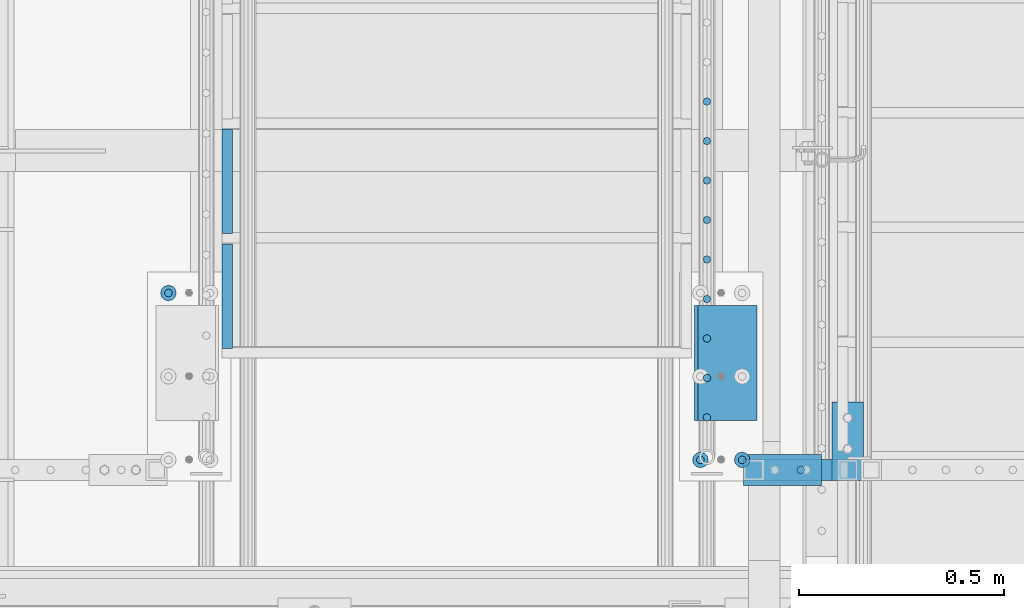
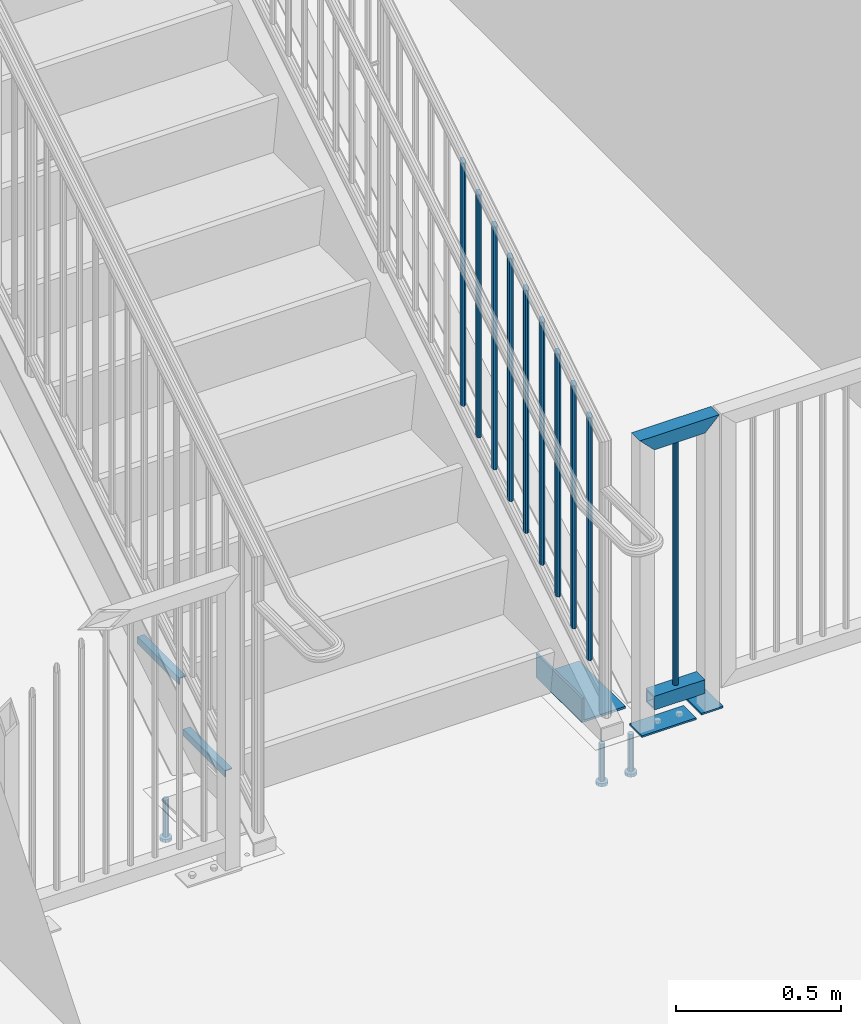
# One storey, part 1260 of 1763: 20 beams, 5 elements without a shape of their own.
"""IFC2X3 building model written with IfcOpenShell, lengths in millimetres."""

from ifc_helpers import new_model, si_unit, frame, origin_with_axes, place, context, subcontext, project, spatial, faceted_brep, material, type_object, element, aggregate, save


model = new_model("IFC2X3")

# Units and contexts
model_context = context("Model", 3, precision=1e-05, world=origin_with_axes())
body_context = subcontext(model_context, "Body", "Model", "MODEL_VIEW")
ifc_project = project(units=[si_unit("LENGTHUNIT", "METRE", prefix="MILLI"), si_unit("AREAUNIT", "SQUARE_METRE"), si_unit("VOLUMEUNIT", "CUBIC_METRE"), si_unit("MASSUNIT", "GRAM", prefix="KILO"), si_unit("TIMEUNIT", "SECOND"), si_unit("PLANEANGLEUNIT", "RADIAN"), si_unit("SOLIDANGLEUNIT", "STERADIAN"), si_unit("THERMODYNAMICTEMPERATUREUNIT", "DEGREE_CELSIUS"), si_unit("LUMINOUSINTENSITYUNIT", "LUMEN")], contexts=[model_context])

# Site, building, storey
site_placement = place(None, origin_with_axes())
site = spatial("IfcSite", under=ifc_project, at=site_placement, CompositionType="ELEMENT")
building_placement = place(site_placement, origin_with_axes())
building = spatial("IfcBuilding", under=site, at=building_placement, Name="Undefined", CompositionType="ELEMENT")
storey_placement = place(building_placement, origin_with_axes())
storey = spatial("IfcBuildingStorey", under=building, at=storey_placement, Name="Undefined", CompositionType="ELEMENT", Elevation=0.0)

# Assembly, beams
assembly_1_placement = place(storey_placement, origin_with_axes())
assembly_1 = element("IfcElementAssembly", 1, at=assembly_1_placement, inside=storey, Name="GUARDRAIL", AssemblyPlace="NOTDEFINED", PredefinedType="RIGID_FRAME")
ifc_material_1 = material(Name="STEEL/A36")
beam_type_1 = type_object("IfcBeamType", PredefinedType="NOTDEFINED")
beam_1_placement = place(assembly_1_placement, frame((-85375.187267589, 32061.1500064728, 307.975030132566), z_axis=(1.0, 0.0, 0.0), x_axis=(0.0, -1.0, 0.0)))
beam_1 = element("IfcBeam", 2, at=beam_1_placement, type_object=beam_type_1, material=ifc_material_1, context=body_context, shape_type="Brep", body=[
    faceted_brep([(0.0, 3.17500000000001, -95.25), (0.0, 3.17499999999927, 95.25), (76.1999968561649, 3.17499999984284, 95.25), (76.1999999999971, 3.17500000000001, -95.25), (0.0, -3.17499999999927, 95.25), (76.1999970403122, -3.17500000015571, 95.25), (0.0, -3.17500000000001, -95.25), (76.1999999999971, -3.17500000000001, -95.25)], [[[0, 1, 2, 3]], [[1, 4, 5, 2]], [[4, 6, 7, 5]], [[6, 0, 3, 7]], [[5, 7, 3, 2]], [[6, 4, 1, 0]]]),
])
beam_2_placement = place(assembly_1_placement, frame((-85254.5046939728, 32092.8674137657, 307.975030132566), z_axis=(0.0, 1.0, 0.0), x_axis=(1.0, 0.0, 0.0)))
beam_2 = element("IfcBeam", 3, at=beam_2_placement, type_object=beam_type_1, material=ifc_material_1, context=body_context, shape_type="Brep", body=[
    faceted_brep([(0.0, 3.17500000000001, -95.25), (0.0, 3.17499999999927, 95.25), (76.1999968561649, 3.17499999984284, 95.25), (76.1999999999971, 3.17500000000001, -95.25), (0.0, -3.17499999999927, 95.25), (76.1999970403122, -3.17500000015571, 95.25), (0.0, -3.17500000000001, -95.25), (76.1999999999971, -3.17500000000001, -95.25)], [[[0, 1, 2, 3]], [[1, 4, 5, 2]], [[4, 6, 7, 5]], [[6, 0, 3, 7]], [[5, 7, 3, 2]], [[6, 4, 1, 0]]]),
])
beam_type_2 = type_object("IfcBeamType", PredefinedType="NOTDEFINED")
beam_3_placement = place(assembly_1_placement, frame((-85330.7372706616, 32023.0500064728, 1346.20003013257), z_axis=(1.0, 0.0, 0.0), x_axis=(0.0, 0.0, -1.0)))
beam_3 = element("IfcBeam", 4, at=beam_3_placement, type_object=beam_type_2, material=ifc_material_1, Name="PICKET", context=body_context, shape_type="Brep", body=[
    faceted_brep([(0.0, -9.52500000000146, 0.0), (0.0, -6.73519209080041, -6.73519209079677), (914.401840643747, -6.73519209080041, -6.73519209079677), (914.401840643747, -9.52500000000146, 0.0), (0.0, 0.0, -9.52499999999418), (914.401840643747, 0.0, -9.52499999999418), (0.0, 6.73519209080041, -6.73519209079677), (914.401840643747, 6.73519209080041, -6.73519209079677), (0.0, 9.52500000000146, 0.0), (914.401840643747, 9.52500000000146, 0.0), (0.0, 6.73519209080041, 6.73519209079677), (914.401840643747, 6.73519209080041, 6.73519209079677), (0.0, 0.0, 9.52499999999418), (914.401840643747, 0.0, 9.52499999999418), (0.0, -6.73519209080041, 6.73519209079677), (914.401840643747, -6.73519209080041, 6.73519209079677)], [[[0, 1, 2, 3]], [[1, 4, 5, 2]], [[4, 6, 7, 5]], [[6, 8, 9, 7]], [[8, 10, 11, 9]], [[10, 12, 13, 11]], [[12, 14, 15, 13]], [[14, 0, 3, 15]], [[5, 7, 9, 11, 13, 15, 3, 2]], [[14, 12, 10, 8, 6, 4, 1, 0]]]),
])

assembly_2_placement = place(storey_placement, origin_with_axes())
assembly_2 = element("IfcElementAssembly", 5, at=assembly_2_placement, inside=storey, Name="RAIL", AssemblyPlace="NOTDEFINED", PredefinedType="RIGID_FRAME")
beam_4_placement = place(assembly_2_placement, frame((-85559.3372736932, 32920.2142860841, 1932.26310525964), z_axis=(-1.0, 0.0, 0.0), x_axis=(0.0, 0.0, -1.0)))
beam_4 = element("IfcBeam", 6, at=beam_4_placement, type_object=beam_type_2, material=ifc_material_1, Name="PICKET", context=body_context, shape_type="Brep", body=[
    faceted_brep([(16.5091072770651, -9.52500000000146, 0.0), (18.2402825153672, -6.73519209080405, -6.73519209079677), (919.550864034841, -6.73519209080405, -6.73519209079677), (917.819688796539, -9.52500000000146, 0.0), (22.4197092545201, 0.0, -9.52499999999418), (923.730290773995, 0.0, -9.52499999999418), (26.5991359936734, 6.73519209080405, -6.73519209079677), (927.909717513148, 6.73519209080405, -6.73519209079677), (28.330311231975, 9.52500000000146, 0.0), (929.64089275145, 9.52500000000146, 0.0), (26.5991359936734, 6.73519209080405, 6.73519209079677), (927.909717513148, 6.73519209080405, 6.73519209079677), (22.4197092545201, 0.0, 9.52499999999418), (923.730290773995, 0.0, 9.52499999999418), (18.2402825153672, -6.73519209080405, 6.73519209079677), (919.550864034841, -6.73519209080405, 6.73519209079677)], [[[0, 1, 2, 3]], [[1, 4, 5, 2]], [[4, 6, 7, 5]], [[6, 8, 9, 7]], [[8, 10, 11, 9]], [[10, 12, 13, 11]], [[12, 14, 15, 13]], [[14, 0, 3, 15]], [[13, 15, 3, 2, 5, 7, 9, 11]], [[14, 12, 10, 8, 6, 4, 1, 0]]]),
])
beam_5_placement = place(assembly_2_placement, frame((-85559.3372736932, 32824.0571432269, 1872.5941710114), z_axis=(-1.0, 0.0, 0.0), x_axis=(0.0, 0.0, -1.0)))
beam_5 = element("IfcBeam", 7, at=beam_5_placement, type_object=beam_type_2, material=ifc_material_1, Name="PICKET", context=body_context, shape_type="Brep", body=[
    faceted_brep([(16.5091072770651, -9.52500000000146, 0.0), (18.2402825153672, -6.73519209080405, -6.73519209079677), (919.550864034841, -6.73519209080405, -6.73519209079677), (917.819688796539, -9.52500000000146, 0.0), (22.4197092545201, 0.0, -9.52499999999418), (923.730290773995, 0.0, -9.52499999999418), (26.5991359936734, 6.73519209080405, -6.73519209079677), (927.909717513148, 6.73519209080405, -6.73519209079677), (28.330311231975, 9.52500000000146, 0.0), (929.64089275145, 9.52500000000146, 0.0), (26.5991359936734, 6.73519209080405, 6.73519209079677), (927.909717513148, 6.73519209080405, 6.73519209079677), (22.4197092545201, 0.0, 9.52499999999418), (923.730290773995, 0.0, 9.52499999999418), (18.2402825153672, -6.73519209080405, 6.73519209079677), (919.550864034841, -6.73519209080405, 6.73519209079677)], [[[0, 1, 2, 3]], [[1, 4, 5, 2]], [[4, 6, 7, 5]], [[6, 8, 9, 7]], [[8, 10, 11, 9]], [[10, 12, 13, 11]], [[12, 14, 15, 13]], [[14, 0, 3, 15]], [[13, 15, 3, 2, 5, 7, 9, 11]], [[14, 12, 10, 8, 6, 4, 1, 0]]]),
])
beam_6_placement = place(assembly_2_placement, frame((-85559.3372736932, 32727.9000003697, 1812.92523676316), z_axis=(-1.0, 0.0, 0.0), x_axis=(0.0, 0.0, -1.0)))
beam_6 = element("IfcBeam", 8, at=beam_6_placement, type_object=beam_type_2, material=ifc_material_1, Name="PICKET", context=body_context, shape_type="Brep", body=[
    faceted_brep([(16.5091072770651, -9.52500000000146, 0.0), (18.2402825153672, -6.73519209080405, -6.73519209079677), (919.550864034841, -6.73519209080405, -6.73519209079677), (917.819688796539, -9.52500000000146, 0.0), (22.4197092545201, 0.0, -9.52499999999418), (923.730290773995, 0.0, -9.52499999999418), (26.5991359936734, 6.73519209080405, -6.73519209079677), (927.909717513148, 6.73519209080405, -6.73519209079677), (28.330311231975, 9.52500000000146, 0.0), (929.64089275145, 9.52500000000146, 0.0), (26.5991359936734, 6.73519209080405, 6.73519209079677), (927.909717513148, 6.73519209080405, 6.73519209079677), (22.4197092545201, 0.0, 9.52499999999418), (923.730290773995, 0.0, 9.52499999999418), (18.2402825153672, -6.73519209080405, 6.73519209079677), (919.550864034841, -6.73519209080405, 6.73519209079677)], [[[0, 1, 2, 3]], [[1, 4, 5, 2]], [[4, 6, 7, 5]], [[6, 8, 9, 7]], [[8, 10, 11, 9]], [[10, 12, 13, 11]], [[12, 14, 15, 13]], [[14, 0, 3, 15]], [[13, 15, 3, 2, 5, 7, 9, 11]], [[14, 12, 10, 8, 6, 4, 1, 0]]]),
])
beam_7_placement = place(assembly_2_placement, frame((-85559.3372736932, 32631.7428575125, 1753.25630251491), z_axis=(-1.0, 0.0, 0.0), x_axis=(0.0, 0.0, -1.0)))
beam_7 = element("IfcBeam", 9, at=beam_7_placement, type_object=beam_type_2, material=ifc_material_1, Name="PICKET", context=body_context, shape_type="Brep", body=[
    faceted_brep([(16.5091072770651, -9.52500000000146, 0.0), (18.2402825153672, -6.73519209080405, -6.73519209079677), (919.550864034841, -6.73519209080405, -6.73519209079677), (917.819688796539, -9.52500000000146, 0.0), (22.4197092545201, 0.0, -9.52499999999418), (923.730290773995, 0.0, -9.52499999999418), (26.5991359936734, 6.73519209080405, -6.73519209079677), (927.909717513148, 6.73519209080405, -6.73519209079677), (28.330311231975, 9.52500000000146, 0.0), (929.64089275145, 9.52500000000146, 0.0), (26.5991359936734, 6.73519209080405, 6.73519209079677), (927.909717513148, 6.73519209080405, 6.73519209079677), (22.4197092545201, 0.0, 9.52499999999418), (923.730290773995, 0.0, 9.52499999999418), (18.2402825153672, -6.73519209080405, 6.73519209079677), (919.550864034841, -6.73519209080405, 6.73519209079677)], [[[0, 1, 2, 3]], [[1, 4, 5, 2]], [[4, 6, 7, 5]], [[6, 8, 9, 7]], [[8, 10, 11, 9]], [[10, 12, 13, 11]], [[12, 14, 15, 13]], [[14, 0, 3, 15]], [[13, 15, 3, 2, 5, 7, 9, 11]], [[14, 12, 10, 8, 6, 4, 1, 0]]]),
])
beam_8_placement = place(assembly_2_placement, frame((-85559.3372736932, 32535.5857146553, 1693.58736826667), z_axis=(-1.0, 0.0, 0.0), x_axis=(0.0, 0.0, -1.0)))
beam_8 = element("IfcBeam", 10, at=beam_8_placement, type_object=beam_type_2, material=ifc_material_1, Name="PICKET", context=body_context, shape_type="Brep", body=[
    faceted_brep([(16.5091072770651, -9.52500000000146, 0.0), (18.2402825153672, -6.73519209080405, -6.73519209079677), (919.550864034841, -6.73519209080405, -6.73519209079677), (917.819688796539, -9.52500000000146, 0.0), (22.4197092545201, 0.0, -9.52499999999418), (923.730290773995, 0.0, -9.52499999999418), (26.5991359936734, 6.73519209080405, -6.73519209079677), (927.909717513148, 6.73519209080405, -6.73519209079677), (28.330311231975, 9.52500000000146, 0.0), (929.64089275145, 9.52500000000146, 0.0), (26.5991359936734, 6.73519209080405, 6.73519209079677), (927.909717513148, 6.73519209080405, 6.73519209079677), (22.4197092545201, 0.0, 9.52499999999418), (923.730290773995, 0.0, 9.52499999999418), (18.2402825153672, -6.73519209080405, 6.73519209079677), (919.550864034841, -6.73519209080405, 6.73519209079677)], [[[0, 1, 2, 3]], [[1, 4, 5, 2]], [[4, 6, 7, 5]], [[6, 8, 9, 7]], [[8, 10, 11, 9]], [[10, 12, 13, 11]], [[12, 14, 15, 13]], [[14, 0, 3, 15]], [[13, 15, 3, 2, 5, 7, 9, 11]], [[14, 12, 10, 8, 6, 4, 1, 0]]]),
])
beam_9_placement = place(assembly_2_placement, frame((-85559.3372736932, 32439.4285717981, 1633.91843401843), z_axis=(-1.0, 0.0, 0.0), x_axis=(0.0, 0.0, -1.0)))
beam_9 = element("IfcBeam", 11, at=beam_9_placement, type_object=beam_type_2, material=ifc_material_1, Name="PICKET", context=body_context, shape_type="Brep", body=[
    faceted_brep([(16.5091072770651, -9.52500000000146, 0.0), (18.2402825153672, -6.73519209080405, -6.73519209079677), (919.550864034841, -6.73519209080405, -6.73519209079677), (917.819688796539, -9.52500000000146, 0.0), (22.4197092545201, 0.0, -9.52499999999418), (923.730290773995, 0.0, -9.52499999999418), (26.5991359936734, 6.73519209080405, -6.73519209079677), (927.909717513148, 6.73519209080405, -6.73519209079677), (28.330311231975, 9.52500000000146, 0.0), (929.64089275145, 9.52500000000146, 0.0), (26.5991359936734, 6.73519209080405, 6.73519209079677), (927.909717513148, 6.73519209080405, 6.73519209079677), (22.4197092545201, 0.0, 9.52499999999418), (923.730290773995, 0.0, 9.52499999999418), (18.2402825153672, -6.73519209080405, 6.73519209079677), (919.550864034841, -6.73519209080405, 6.73519209079677)], [[[0, 1, 2, 3]], [[1, 4, 5, 2]], [[4, 6, 7, 5]], [[6, 8, 9, 7]], [[8, 10, 11, 9]], [[10, 12, 13, 11]], [[12, 14, 15, 13]], [[14, 0, 3, 15]], [[13, 15, 3, 2, 5, 7, 9, 11]], [[14, 12, 10, 8, 6, 4, 1, 0]]]),
])
beam_10_placement = place(assembly_2_placement, frame((-85559.3372736932, 32343.2714289409, 1574.24949977019), z_axis=(-1.0, 0.0, 0.0), x_axis=(0.0, 0.0, -1.0)))
beam_10 = element("IfcBeam", 12, at=beam_10_placement, type_object=beam_type_2, material=ifc_material_1, Name="PICKET", context=body_context, shape_type="Brep", body=[
    faceted_brep([(16.5091072770651, -9.52500000000146, 0.0), (18.2402825153672, -6.73519209080405, -6.73519209079677), (919.550864034841, -6.73519209080405, -6.73519209079677), (917.819688796539, -9.52500000000146, 0.0), (22.4197092545201, 0.0, -9.52499999999418), (923.730290773995, 0.0, -9.52499999999418), (26.5991359936734, 6.73519209080405, -6.73519209079677), (927.909717513148, 6.73519209080405, -6.73519209079677), (28.330311231975, 9.52500000000146, 0.0), (929.64089275145, 9.52500000000146, 0.0), (26.5991359936734, 6.73519209080405, 6.73519209079677), (927.909717513148, 6.73519209080405, 6.73519209079677), (22.4197092545201, 0.0, 9.52499999999418), (923.730290773995, 0.0, 9.52499999999418), (18.2402825153672, -6.73519209080405, 6.73519209079677), (919.550864034841, -6.73519209080405, 6.73519209079677)], [[[0, 1, 2, 3]], [[1, 4, 5, 2]], [[4, 6, 7, 5]], [[6, 8, 9, 7]], [[8, 10, 11, 9]], [[10, 12, 13, 11]], [[12, 14, 15, 13]], [[14, 0, 3, 15]], [[13, 15, 3, 2, 5, 7, 9, 11]], [[14, 12, 10, 8, 6, 4, 1, 0]]]),
])
beam_11_placement = place(assembly_2_placement, frame((-85559.3372736932, 32247.1142860837, 1514.58056552195), z_axis=(-1.0, 0.0, 0.0), x_axis=(0.0, 0.0, -1.0)))
beam_11 = element("IfcBeam", 13, at=beam_11_placement, type_object=beam_type_2, material=ifc_material_1, Name="PICKET", context=body_context, shape_type="Brep", body=[
    faceted_brep([(16.5091072770651, -9.52500000000146, 0.0), (18.2402825153672, -6.73519209080405, -6.73519209079677), (919.550864034841, -6.73519209080405, -6.73519209079677), (917.819688796539, -9.52500000000146, 0.0), (22.4197092545201, 0.0, -9.52499999999418), (923.730290773995, 0.0, -9.52499999999418), (26.5991359936734, 6.73519209080405, -6.73519209079677), (927.909717513148, 6.73519209080405, -6.73519209079677), (28.330311231975, 9.52500000000146, 0.0), (929.64089275145, 9.52500000000146, 0.0), (26.5991359936734, 6.73519209080405, 6.73519209079677), (927.909717513148, 6.73519209080405, 6.73519209079677), (22.4197092545201, 0.0, 9.52499999999418), (923.730290773995, 0.0, 9.52499999999418), (18.2402825153672, -6.73519209080405, 6.73519209079677), (919.550864034841, -6.73519209080405, 6.73519209079677)], [[[0, 1, 2, 3]], [[1, 4, 5, 2]], [[4, 6, 7, 5]], [[6, 8, 9, 7]], [[8, 10, 11, 9]], [[10, 12, 13, 11]], [[12, 14, 15, 13]], [[14, 0, 3, 15]], [[13, 15, 3, 2, 5, 7, 9, 11]], [[14, 12, 10, 8, 6, 4, 1, 0]]]),
])
beam_12_placement = place(assembly_2_placement, frame((-85559.3372736932, 32150.9571432265, 1454.9116312737), z_axis=(-1.0, 0.0, 0.0), x_axis=(0.0, 0.0, -1.0)))
beam_12 = element("IfcBeam", 14, at=beam_12_placement, type_object=beam_type_2, material=ifc_material_1, Name="PICKET", context=body_context, shape_type="Brep", body=[
    faceted_brep([(16.5091072770651, -9.52500000000146, 0.0), (18.2402825153672, -6.73519209080405, -6.73519209079677), (919.550864034841, -6.73519209080405, -6.73519209079677), (917.819688796539, -9.52500000000146, 0.0), (22.4197092545201, 0.0, -9.52499999999418), (923.730290773995, 0.0, -9.52499999999418), (26.5991359936734, 6.73519209080405, -6.73519209079677), (927.909717513148, 6.73519209080405, -6.73519209079677), (28.330311231975, 9.52500000000146, 0.0), (929.64089275145, 9.52500000000146, 0.0), (26.5991359936734, 6.73519209080405, 6.73519209079677), (927.909717513148, 6.73519209080405, 6.73519209079677), (22.4197092545201, 0.0, 9.52499999999418), (923.730290773995, 0.0, 9.52499999999418), (18.2402825153672, -6.73519209080405, 6.73519209079677), (919.550864034841, -6.73519209080405, 6.73519209079677)], [[[0, 1, 2, 3]], [[1, 4, 5, 2]], [[4, 6, 7, 5]], [[6, 8, 9, 7]], [[8, 10, 11, 9]], [[10, 12, 13, 11]], [[12, 14, 15, 13]], [[14, 0, 3, 15]], [[13, 15, 3, 2, 5, 7, 9, 11]], [[14, 12, 10, 8, 6, 4, 1, 0]]]),
])
aggregate(assembly_2, [beam_4, beam_5, beam_6, beam_7, beam_8, beam_9, beam_10, beam_11, beam_12])

# Beam
ifc_material_2 = material()
beam_type_3 = type_object("IfcBeamType", Name="HSS2X2X1/4", PredefinedType="NOTDEFINED")
beam_13_placement = place(assembly_1_placement, frame((-85445.037267589, 32023.0500064728, 406.39818948882), z_axis=(0.0, 0.0, 1.0), x_axis=(1.0, 0.0, 0.0)))
beam_13 = element("IfcBeam", 15, at=beam_13_placement, type_object=beam_type_3, material=ifc_material_2, Name="GUARDRAIL", ObjectType="HSS2X2X1/4", context=body_context, shape_type="Brep", body=[
    faceted_brep([(25.3999999999942, 19.0499999999993, -19.05), (25.3999999999942, -19.0499999999993, -19.05), (203.199993854709, -19.0499999999993, -19.05), (203.199993854709, 19.0499999999993, -19.05), (25.3999999999942, -19.0499999999993, 19.05), (203.199993854709, -19.0499999999993, 19.05), (25.3999999999942, 19.0499999999993, 19.05), (203.199993854709, 19.0499999999993, 19.05), (25.400000000006, 25.4000000000015, -25.3999999999942), (25.4000000000001, 25.4000000000015, 25.3999999999942), (203.199993854709, 25.4000000000015, 25.4), (203.199993854709, 25.4000000000015, -25.4), (25.4000000000001, -25.4000000000015, 25.3999999999942), (203.199993854709, -25.4000000000015, 25.4), (25.400000000006, -25.4000000000015, -25.3999999999942), (203.199993854709, -25.4000000000015, -25.4)], [[[0, 1, 2, 3]], [[1, 4, 5, 2]], [[4, 6, 7, 5]], [[6, 0, 3, 7]], [[8, 9, 10, 11]], [[9, 12, 13, 10]], [[12, 14, 15, 13]], [[14, 8, 11, 15]], [[13, 15, 11, 10], [5, 7, 3, 2]], [[14, 12, 9, 8], [6, 4, 1, 0]]]),
])

beam_14_placement = place(assembly_1_placement, frame((-85445.037267589, 32023.0500064728, 1371.60003013257), z_axis=(0.0, 0.0, 1.0), x_axis=(1.0, 0.0, 0.0)))
beam_14 = element("IfcBeam", 16, at=beam_14_placement, type_object=beam_type_3, material=ifc_material_2, Name="GUARDRAIL", ObjectType="HSS2X2X1/4", context=body_context, shape_type="Brep", body=[
    faceted_brep([(19.0500000000052, 19.0499999999993, -19.0500000000029), (19.0500000000052, -19.0499999999993, -19.0500000000029), (209.5499938547, -19.0499999999993, -19.05), (209.5499938547, 19.0499999999993, -19.05), (-19.0499999999993, -19.0499999999993, 19.0500000000029), (247.649993854691, -19.0499999999993, 19.05), (-19.0499999999993, 19.0499999999993, 19.0500000000029), (247.649993854691, 19.0499999999993, 19.05), (25.400000000006, 25.4000000000015, -25.3999999999942), (-25.4000000000001, 25.4000000000015, 25.3999999999942), (253.999993854697, 25.4000000000015, 25.4000000000001), (203.199993854709, 25.4000000000015, -25.4), (-25.4000000000001, -25.4000000000015, 25.3999999999942), (253.999993854697, -25.4000000000015, 25.4000000000001), (25.400000000006, -25.4000000000015, -25.3999999999942), (203.199993854709, -25.4000000000015, -25.4)], [[[0, 1, 2, 3]], [[1, 4, 5, 2]], [[4, 6, 7, 5]], [[6, 0, 3, 7]], [[8, 9, 10, 11]], [[9, 12, 13, 10]], [[12, 14, 15, 13]], [[14, 8, 11, 15]], [[13, 15, 11, 10], [5, 7, 3, 2]], [[14, 12, 9, 8], [6, 4, 1, 0]]]),
])

aggregate(assembly_1, [beam_1, beam_2, beam_3, beam_13, beam_14])

# Assembly, beam
assembly_3_placement = place(storey_placement, origin_with_axes())
assembly_3 = element("IfcElementAssembly", 17, at=assembly_3_placement, inside=storey, Name="STRINGER", AssemblyPlace="NOTDEFINED", PredefinedType="RIGID_FRAME")
beam_type_4 = type_object("IfcBeamType", Name="L6X3-1/2X5/16", PredefinedType="NOTDEFINED")
beam_15_placement = place(assembly_3_placement, frame((-85513.2997737343, 32423.1000003621, 349.249782501801), z_axis=(1.0, 0.0, 0.0), x_axis=(0.0, -1.0, 0.0)))
beam_15 = element("IfcBeam", 18, at=beam_15_placement, type_object=beam_type_4, material=ifc_material_1, Name="ANGLE", ObjectType="L6X3-1/2X5/16", context=body_context, shape_type="Brep", body=[
    faceted_brep([(0.0, 44.45, -76.1999999999971), (0.0, 44.45, 76.1999999999971), (279.400000000001, 44.45, 76.1999999999971), (279.400000000001, 44.45, -76.1999999999971), (0.0, 36.5125, 76.1999999999971), (279.400000000001, 36.5125, 76.1999999999971), (0.0, 36.5125, -68.2624999999971), (279.400000000001, 36.5125, -68.2624999999971), (0.0, -44.45, -68.2624999999971), (279.400000000001, -44.45, -68.2624999999971), (0.0, -44.45, -76.1999999999971), (279.400000000001, -44.45, -76.1999999999971)], [[[0, 1, 2, 3]], [[1, 4, 5, 2]], [[4, 6, 7, 5]], [[6, 8, 9, 7]], [[8, 10, 11, 9]], [[10, 0, 3, 11]], [[5, 7, 9, 11, 3, 2]], [[10, 8, 6, 4, 1, 0]]]),
])

# Assembly, beams
assembly_4_placement = place(storey_placement, origin_with_axes())
assembly_4 = element("IfcElementAssembly", 19, at=assembly_4_placement, inside=storey, Name="PLATE", AssemblyPlace="NOTDEFINED", PredefinedType="RIGID_FRAME")
ifc_material_3 = material(Name="STEEL/A108")
beam_type_5 = type_object("IfcBeamType", Name="STUD_3/4-DIA", PredefinedType="NOTDEFINED")
beam_16_placement = place(assembly_4_placement, frame((-85575.2122767855, 32047.5777095314, 285.749960436517), z_axis=(-1.0, 0.0, 0.0), x_axis=(0.0, 0.0, -1.0)))
beam_16 = element("IfcBeam", 20, at=beam_16_placement, type_object=beam_type_5, material=ifc_material_3, Name="BEAM", ObjectType="STUD_3/4-DIA", context=body_context, shape_type="Brep", body=[
    faceted_brep([(0.0, -9.52000045776367, 0.0), (0.0, -8.25, -4.76000022888184), (138.684, -8.25, -4.76000022888184), (138.684, -9.52000045776367, 0.0), (0.0, -4.76000022888184, -8.25), (138.684, -4.76000022888184, -8.25), (0.0, 0.0, -9.52000045776367), (138.684, 0.0, -9.52000045776367), (0.0, 4.76000022888184, -8.25), (138.684, 4.76000022888184, -8.25), (0.0, 8.25, -4.76000022888184), (138.684, 8.25, -4.76000022888184), (0.0, 9.52000045776367, 0.0), (138.684, 9.52000045776367, 0.0), (0.0, 8.25, 4.76000022888184), (138.684, 8.25, 4.76000022888184), (0.0, 4.76000022888184, 8.25), (138.684, 4.76000022888184, 8.25), (0.0, 0.0, 9.52000045776367), (138.684, 0.0, 9.52000045776367), (0.0, -4.76000022888184, 8.25), (138.684, -4.76000022888184, 8.25), (0.0, -8.25, 4.76000022888184), (138.684, -8.25, 4.76000022888184), (140.208, -16.5, -9.52000045776367), (140.208, -19.0499992370605, 0.0), (140.208, -9.52000045776367, -16.5), (140.208, 0.0, -19.0499992370605), (140.208, 9.52000045776367, -16.5), (140.208, 16.5, -9.52000045776367), (140.208, 19.0499992370605, 0.0), (140.208, 16.5, 9.52000045776367), (140.208, 9.52000045776367, 16.5), (140.208, 0.0, 19.0499992370605), (140.208, -9.52000045776367, 16.5), (140.208, -16.5, 9.52000045776367), (152.4, -16.5, -9.52000045776367), (152.4, -19.0499992370605, 0.0), (152.4, -9.52000045776367, -16.5), (152.4, 0.0, -19.0499992370605), (152.4, 9.52000045776367, -16.5), (152.4, 16.5, -9.52000045776367), (152.4, 19.0499992370605, 0.0), (152.4, 16.5, 9.52000045776367), (152.4, 9.52000045776367, 16.5), (152.4, 0.0, 19.0499992370605), (152.4, -9.52000045776367, 16.5), (152.4, -16.5, 9.52000045776367)], [[[0, 1, 2, 3]], [[1, 4, 5, 2]], [[4, 6, 7, 5]], [[6, 8, 9, 7]], [[8, 10, 11, 9]], [[10, 12, 13, 11]], [[12, 14, 15, 13]], [[14, 16, 17, 15]], [[16, 18, 19, 17]], [[18, 20, 21, 19]], [[20, 22, 23, 21]], [[22, 0, 3, 23]], [[22, 20, 18, 16, 14, 12, 10, 8, 6, 4, 1, 0]], [[3, 2, 24, 25]], [[2, 5, 26, 24]], [[5, 7, 27, 26]], [[7, 9, 28, 27]], [[9, 11, 29, 28]], [[11, 13, 30, 29]], [[13, 15, 31, 30]], [[15, 17, 32, 31]], [[17, 19, 33, 32]], [[19, 21, 34, 33]], [[21, 23, 35, 34]], [[23, 3, 25, 35]], [[25, 24, 36, 37]], [[24, 26, 38, 36]], [[26, 27, 39, 38]], [[27, 28, 40, 39]], [[28, 29, 41, 40]], [[29, 30, 42, 41]], [[30, 31, 43, 42]], [[31, 32, 44, 43]], [[32, 33, 45, 44]], [[33, 34, 46, 45]], [[34, 35, 47, 46]], [[35, 25, 37, 47]], [[38, 39, 40, 41, 42, 43, 44, 45, 46, 47, 37, 36]]]),
])
beam_17_placement = place(assembly_4_placement, frame((-85473.6122767855, 32047.5777095314, 285.749960436508), z_axis=(-1.0, 0.0, 0.0), x_axis=(0.0, 0.0, -1.0)))
beam_17 = element("IfcBeam", 21, at=beam_17_placement, type_object=beam_type_5, material=ifc_material_3, Name="BEAM", ObjectType="STUD_3/4-DIA", context=body_context, shape_type="Brep", body=[
    faceted_brep([(0.0, -9.52000045776367, 0.0), (0.0, -8.25, -4.76000022888184), (138.684, -8.25, -4.76000022888184), (138.684, -9.52000045776367, 0.0), (0.0, -4.76000022888184, -8.25), (138.684, -4.76000022888184, -8.25), (0.0, 0.0, -9.52000045776367), (138.684, 0.0, -9.52000045776367), (0.0, 4.76000022888184, -8.25), (138.684, 4.76000022888184, -8.25), (0.0, 8.25, -4.76000022888184), (138.684, 8.25, -4.76000022888184), (0.0, 9.52000045776367, 0.0), (138.684, 9.52000045776367, 0.0), (0.0, 8.25, 4.76000022888184), (138.684, 8.25, 4.76000022888184), (0.0, 4.76000022888184, 8.25), (138.684, 4.76000022888184, 8.25), (0.0, 0.0, 9.52000045776367), (138.684, 0.0, 9.52000045776367), (0.0, -4.76000022888184, 8.25), (138.684, -4.76000022888184, 8.25), (0.0, -8.25, 4.76000022888184), (138.684, -8.25, 4.76000022888184), (140.208, -16.5, -9.52000045776367), (140.208, -19.0499992370605, 0.0), (140.208, -9.52000045776367, -16.5), (140.208, 0.0, -19.0499992370605), (140.208, 9.52000045776367, -16.5), (140.208, 16.5, -9.52000045776367), (140.208, 19.0499992370605, 0.0), (140.208, 16.5, 9.52000045776367), (140.208, 9.52000045776367, 16.5), (140.208, 0.0, 19.0499992370605), (140.208, -9.52000045776367, 16.5), (140.208, -16.5, 9.52000045776367), (152.4, -16.5, -9.52000045776367), (152.4, -19.0499992370605, 0.0), (152.4, -9.52000045776367, -16.5), (152.4, 0.0, -19.0499992370605), (152.4, 9.52000045776367, -16.5), (152.4, 16.5, -9.52000045776367), (152.4, 19.0499992370605, 0.0), (152.4, 16.5, 9.52000045776367), (152.4, 9.52000045776367, 16.5), (152.4, 0.0, 19.0499992370605), (152.4, -9.52000045776367, 16.5), (152.4, -16.5, 9.52000045776367)], [[[0, 1, 2, 3]], [[1, 4, 5, 2]], [[4, 6, 7, 5]], [[6, 8, 9, 7]], [[8, 10, 11, 9]], [[10, 12, 13, 11]], [[12, 14, 15, 13]], [[14, 16, 17, 15]], [[16, 18, 19, 17]], [[18, 20, 21, 19]], [[20, 22, 23, 21]], [[22, 0, 3, 23]], [[22, 20, 18, 16, 14, 12, 10, 8, 6, 4, 1, 0]], [[3, 2, 24, 25]], [[2, 5, 26, 24]], [[5, 7, 27, 26]], [[7, 9, 28, 27]], [[9, 11, 29, 28]], [[11, 13, 30, 29]], [[13, 15, 31, 30]], [[15, 17, 32, 31]], [[17, 19, 33, 32]], [[19, 21, 34, 33]], [[21, 23, 35, 34]], [[23, 3, 25, 35]], [[25, 24, 36, 37]], [[24, 26, 38, 36]], [[26, 27, 39, 38]], [[27, 28, 40, 39]], [[28, 29, 41, 40]], [[29, 30, 42, 41]], [[30, 31, 43, 42]], [[31, 32, 44, 43]], [[32, 33, 45, 44]], [[33, 34, 46, 45]], [[34, 35, 47, 46]], [[35, 25, 37, 47]], [[38, 39, 40, 41, 42, 43, 44, 45, 46, 47, 37, 36]]]),
])
aggregate(assembly_4, [beam_16, beam_17])

# Assembly, beam
assembly_5_placement = place(storey_placement, origin_with_axes())
assembly_5 = element("IfcElementAssembly", 22, at=assembly_5_placement, inside=storey, Name="PLATE", AssemblyPlace="NOTDEFINED", PredefinedType="RIGID_FRAME")
beam_18_placement = place(assembly_5_placement, frame((-86870.6122706704, 32453.9777095314, 285.750030132556), z_axis=(1.0, 0.0, 0.0), x_axis=(0.0, 0.0, -1.0)))
beam_18 = element("IfcBeam", 23, at=beam_18_placement, type_object=beam_type_5, material=ifc_material_3, Name="BEAM", ObjectType="STUD_3/4-DIA", context=body_context, shape_type="Brep", body=[
    faceted_brep([(0.0, -9.52000045776367, 0.0), (0.0, -8.25, -4.76000022888184), (138.684, -8.25, -4.76000022888184), (138.684, -9.52000045776367, 0.0), (0.0, -4.76000022888184, -8.25), (138.684, -4.76000022888184, -8.25), (0.0, 0.0, -9.52000045776367), (138.684, 0.0, -9.52000045776367), (0.0, 4.76000022888184, -8.25), (138.684, 4.76000022888184, -8.25), (0.0, 8.25, -4.76000022888184), (138.684, 8.25, -4.76000022888184), (0.0, 9.52000045776367, 0.0), (138.684, 9.52000045776367, 0.0), (0.0, 8.25, 4.76000022888184), (138.684, 8.25, 4.76000022888184), (0.0, 4.76000022888184, 8.25), (138.684, 4.76000022888184, 8.25), (0.0, 0.0, 9.52000045776367), (138.684, 0.0, 9.52000045776367), (0.0, -4.76000022888184, 8.25), (138.684, -4.76000022888184, 8.25), (0.0, -8.25, 4.76000022888184), (138.684, -8.25, 4.76000022888184), (140.208, -16.5, -9.52000045776367), (140.208, -19.0499992370605, 0.0), (140.208, -9.52000045776367, -16.5), (140.208, 0.0, -19.0499992370605), (140.208, 9.52000045776367, -16.5), (140.208, 16.5, -9.52000045776367), (140.208, 19.0499992370605, 0.0), (140.208, 16.5, 9.52000045776367), (140.208, 9.52000045776367, 16.5), (140.208, 0.0, 19.0499992370605), (140.208, -9.52000045776367, 16.5), (140.208, -16.5, 9.52000045776367), (152.4, -16.5, -9.52000045776367), (152.4, -19.0499992370605, 0.0), (152.4, -9.52000045776367, -16.5), (152.4, 0.0, -19.0499992370605), (152.4, 9.52000045776367, -16.5), (152.4, 16.5, -9.52000045776367), (152.4, 19.0499992370605, 0.0), (152.4, 16.5, 9.52000045776367), (152.4, 9.52000045776367, 16.5), (152.4, 0.0, 19.0499992370605), (152.4, -9.52000045776367, 16.5), (152.4, -16.5, 9.52000045776367)], [[[0, 1, 2, 3]], [[1, 4, 5, 2]], [[4, 6, 7, 5]], [[6, 8, 9, 7]], [[8, 10, 11, 9]], [[10, 12, 13, 11]], [[12, 14, 15, 13]], [[14, 16, 17, 15]], [[16, 18, 19, 17]], [[18, 20, 21, 19]], [[20, 22, 23, 21]], [[22, 0, 3, 23]], [[22, 20, 18, 16, 14, 12, 10, 8, 6, 4, 1, 0]], [[3, 2, 24, 25]], [[2, 5, 26, 24]], [[5, 7, 27, 26]], [[7, 9, 28, 27]], [[9, 11, 29, 28]], [[11, 13, 30, 29]], [[13, 15, 31, 30]], [[15, 17, 32, 31]], [[17, 19, 33, 32]], [[19, 21, 34, 33]], [[21, 23, 35, 34]], [[23, 3, 25, 35]], [[25, 24, 36, 37]], [[24, 26, 38, 36]], [[26, 27, 39, 38]], [[27, 28, 40, 39]], [[28, 29, 41, 40]], [[29, 30, 42, 41]], [[30, 31, 43, 42]], [[31, 32, 44, 43]], [[32, 33, 45, 44]], [[33, 34, 46, 45]], [[34, 35, 47, 46]], [[35, 25, 37, 47]], [[38, 39, 40, 41, 42, 43, 44, 45, 46, 47, 37, 36]]]),
])
aggregate(assembly_5, [beam_18])

# Beam
beam_type_6 = type_object("IfcBeamType", Name="L1X1X1/8", PredefinedType="NOTDEFINED")
beam_19_placement = place(assembly_3_placement, frame((-86727.7372739122, 32598.8511407179, 584.880357333434), z_axis=(1.0, 0.0, 0.0), x_axis=(0.0, 1.0, 0.0)))
beam_19 = element("IfcBeam", 24, at=beam_19_placement, type_object=beam_type_6, material=ifc_material_1, Name="ANGLE", ObjectType="L1X1X1/8", context=body_context, shape_type="Brep", body=[
    faceted_brep([(3.93434019839663e-12, 12.6999999999978, -12.6999998092651), (-1.31614667686587e-12, 12.6999999999978, 12.6999998092651), (254.0, 12.69999981, 12.6999998099927), (254.0, 12.69999981, -12.6999998099927), (-1.06936913171421e-12, 9.52499999999854, 12.699999332428), (254.0, 9.52499985799977, 12.6999998099927), (0.0, 9.52499985799977, -9.52499985799659), (254.0, 9.52499985799977, -9.52499985799659), (0.0, -12.69999981, -9.52499985799659), (254.0, -12.69999981, -9.52499985799659), (0.0, -12.69999981, -12.6999998099927), (254.0, -12.69999981, -12.6999998099927)], [[[0, 1, 2, 3]], [[1, 4, 5, 2]], [[4, 6, 7, 5]], [[6, 8, 9, 7]], [[8, 10, 11, 9]], [[10, 0, 3, 11]], [[5, 7, 9, 11, 3, 2]], [[10, 8, 6, 4, 1, 0]]]),
])

beam_20_placement = place(assembly_3_placement, frame((-86727.7372739122, 32319.4511407179, 411.502678762005), z_axis=(1.0, 0.0, 0.0), x_axis=(0.0, 1.0, 0.0)))
beam_20 = element("IfcBeam", 25, at=beam_20_placement, type_object=beam_type_6, material=ifc_material_1, Name="ANGLE", ObjectType="L1X1X1/8", context=body_context, shape_type="Brep", body=[
    faceted_brep([(3.93434019839663e-12, 12.6999999999978, -12.6999998092651), (-1.31614667686587e-12, 12.6999999999978, 12.6999998092651), (254.0, 12.69999981, 12.6999998099927), (254.0, 12.69999981, -12.6999998099927), (-1.06936913171421e-12, 9.52499999999854, 12.699999332428), (254.0, 9.52499985799977, 12.6999998099927), (0.0, 9.52499985799977, -9.52499985799659), (254.0, 9.52499985799977, -9.52499985799659), (0.0, -12.69999981, -9.52499985799659), (254.0, -12.69999981, -9.52499985799659), (0.0, -12.69999981, -12.6999998099927), (254.0, -12.69999981, -12.6999998099927)], [[[0, 1, 2, 3]], [[1, 4, 5, 2]], [[4, 6, 7, 5]], [[6, 8, 9, 7]], [[8, 10, 11, 9]], [[10, 0, 3, 11]], [[5, 7, 9, 11, 3, 2]], [[10, 8, 6, 4, 1, 0]]]),
])

aggregate(assembly_3, [beam_15, beam_19, beam_20])

save(model, "model.ifc")
